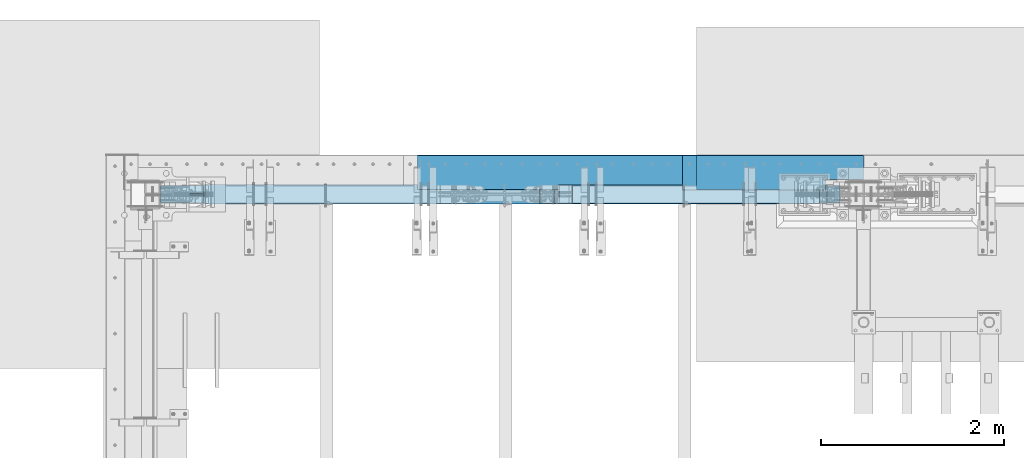
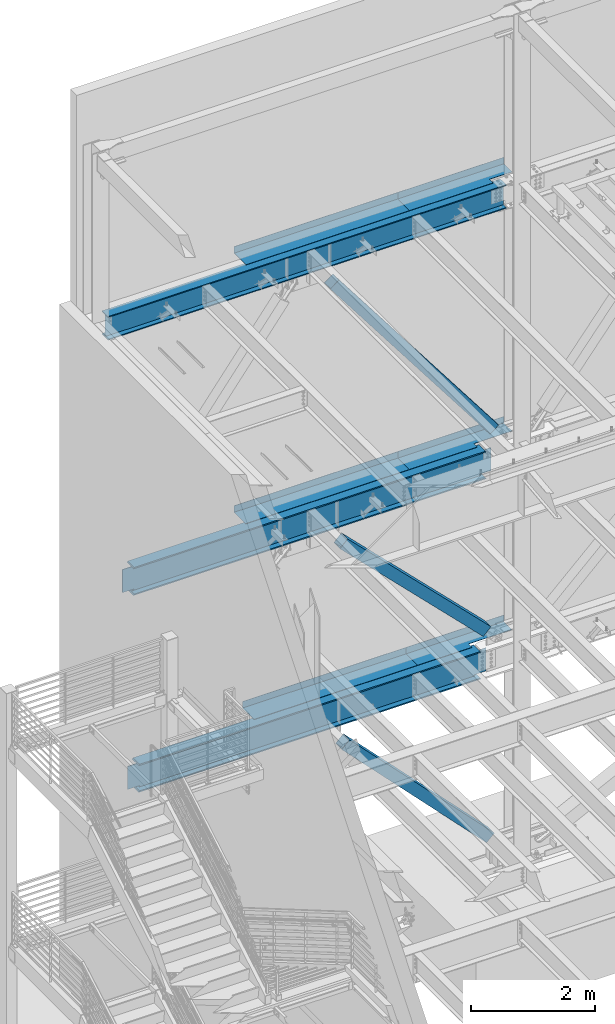
# One storey, part 769 of 1179: 9 beams, 3 members, 6 elements without a shape of their own.
"""IFC2X3 building model written with IfcOpenShell, lengths in millimetres."""

from ifc_helpers import new_model, si_unit, frame, origin_with_axes, place, context, subcontext, project, spatial, faceted_brep, material, type_object, element, aggregate, save


model = new_model("IFC2X3")

# Units and contexts
model_context = context("Model", 3, precision=1e-05, world=origin_with_axes())
body_context = subcontext(model_context, "Body", "Model", "MODEL_VIEW")
ifc_project = project(units=[si_unit("LENGTHUNIT", "METRE", prefix="MILLI"), si_unit("AREAUNIT", "SQUARE_METRE"), si_unit("VOLUMEUNIT", "CUBIC_METRE"), si_unit("MASSUNIT", "GRAM", prefix="KILO"), si_unit("TIMEUNIT", "SECOND"), si_unit("PLANEANGLEUNIT", "RADIAN"), si_unit("SOLIDANGLEUNIT", "STERADIAN"), si_unit("THERMODYNAMICTEMPERATUREUNIT", "DEGREE_CELSIUS"), si_unit("LUMINOUSINTENSITYUNIT", "LUMEN")], contexts=[model_context])

# Site, building, storey
site_placement = place(None, origin_with_axes())
site = spatial("IfcSite", under=ifc_project, at=site_placement, CompositionType="ELEMENT")
building_placement = place(site_placement, origin_with_axes())
building = spatial("IfcBuilding", under=site, at=building_placement, Name="Undefined", CompositionType="ELEMENT")
storey_placement = place(building_placement, origin_with_axes())
storey = spatial("IfcBuildingStorey", under=building, at=storey_placement, Name="Undefined", CompositionType="ELEMENT", Elevation=0.0)

# Assembly, beams
assembly_1_placement = place(storey_placement, origin_with_axes())
assembly_1 = element("IfcElementAssembly", 1, at=assembly_1_placement, inside=storey, Name="BEAM", AssemblyPlace="NOTDEFINED", PredefinedType="RIGID_FRAME")
ifc_material_1 = material(Name="STEEL/A36")
beam_type_1 = type_object("IfcBeamType", PredefinedType="NOTDEFINED")
beam_1_placement = place(assembly_1_placement, frame((7288.212, 41244.8379999672, 13122.275), z_axis=(-1.0, 0.0, 0.0), x_axis=(0.0, 1.0, 0.0)))
beam_1 = element("IfcBeam", 2, at=beam_1_placement, type_object=beam_type_1, material=ifc_material_1, Name="BENT_PLATE", context=body_context, shape_type="Brep", body=[
    faceted_brep([(117.47450003276, -3.17499999999927, -573.284734006237), (117.47450003276, 3.17499999999927, -573.284734006237), (117.47450003276, 3.17499999999927, -989.0125), (117.47450003276, -3.17499999999927, -989.0125), (0.0, -3.17499999999927, -573.284734006237), (0.0, 3.17499999999927, -573.284734006237), (385.761999997871, 3.17499999999927, 989.0125), (0.0, 3.17499999999927, 989.0125), (0.0, -3.17499999999927, 989.0125), (379.411999997865, -3.17499999999927, 989.0125), (379.411999997865, -130.17500000214, 989.0125), (385.761999997871, -130.17500000214, 989.0125), (385.761999997871, 3.17499999999927, -989.0125), (385.761999997871, -130.17500000214, -989.0125), (379.411999997865, -130.17500000214, -989.0125), (379.411999997865, -3.17499999999927, -989.0125)], [[[0, 1, 2, 3]], [[4, 5, 1, 0]], [[6, 7, 8, 9, 10, 11]], [[12, 6, 11, 13]], [[10, 14, 13, 11]], [[9, 15, 14, 10]], [[12, 13, 14, 15, 3, 2]], [[7, 6, 12, 2, 1, 5]], [[8, 7, 5, 4]], [[15, 9, 8, 4, 0, 3]]]),
])
beam_2_placement = place(assembly_1_placement, frame((4775.1995, 41244.838, 13122.275), z_axis=(-1.0, 0.0, 0.0), x_axis=(0.0, 1.0, 0.0)))
beam_2 = element("IfcBeam", 3, at=beam_2_placement, type_object=beam_type_1, material=ifc_material_1, Name="BENT_PLATE", context=body_context, shape_type="Brep", body=[
    faceted_brep([(0.0, -3.17499999999927, -1524.0), (6.00266503170133e-10, -3.17499999922438, 1524.00000000052), (6.00266503170133e-10, 3.17500000077416, 1524.00000000052), (0.0, 3.17499999999927, -1524.0), (385.762000000002, 3.17499999999927, 1524.0), (385.762000000002, 3.17499999999927, -1524.0), (379.411999999997, -3.17499999999927, -1524.0), (379.411999999997, -3.17499999999927, 1524.0), (385.762000000002, -130.175000000001, 1524.0), (385.762000000002, -130.175000000001, -1524.0), (379.411999999997, -130.175000000001, 1524.0), (379.411999999997, -130.175000000001, -1524.0)], [[[0, 1, 2, 3]], [[3, 2, 4, 5]], [[1, 0, 6, 7]], [[5, 4, 8, 9]], [[4, 2, 1, 7, 10, 8]], [[7, 6, 11, 10]], [[6, 0, 3, 5, 9, 11]], [[10, 11, 9, 8]]]),
])

assembly_2_placement = place(storey_placement, origin_with_axes())
assembly_2 = element("IfcElementAssembly", 4, at=assembly_2_placement, inside=storey, Name="BEAM", AssemblyPlace="NOTDEFINED", PredefinedType="RIGID_FRAME")
beam_type_2 = type_object("IfcBeamType", PredefinedType="NOTDEFINED")
beam_3_placement = place(assembly_2_placement, frame((7365.99998779297, 41627.425, 4235.45000610352), z_axis=(1.0, 0.0, 0.0), x_axis=(0.0, 0.0, -1.0)))
beam_3 = element("IfcBeam", 5, at=beam_3_placement, type_object=beam_type_2, material=ifc_material_1, Name="BENT_PLATE", context=body_context, shape_type="Brep", body=[
    faceted_brep([(133.350006103513, -373.062500000007, 103.381845299587), (133.350006103513, -265.112500017596, 103.381845299558), (127.000006103513, -265.112500017596, 103.381845299558), (127.000006103513, -373.062500000007, 103.381845299587), (133.350006103513, -265.112499987561, 911.224999999999), (127.000006103513, -265.112499987561, 911.224999999999), (127.000006103513, -3.17500000000291, -911.225), (0.0, -3.17500000000291, -911.225), (0.0, 3.17500000000291, -911.225), (133.350006103513, 3.17500000000291, -911.225), (133.350006103513, -373.062500000007, -911.225), (127.000006103513, -373.062500000007, -911.225), (0.0, -3.17500000000291, 911.224999999999), (127.000006103513, -3.17500000000291, 911.224999999999), (0.0, 3.17500000000291, 911.224999999999), (133.350006103513, 3.17500000000291, 911.224999999999)], [[[0, 1, 2, 3]], [[4, 5, 2, 1]], [[6, 7, 8, 9, 10, 11]], [[12, 7, 6, 13]], [[7, 12, 14, 8]], [[8, 14, 15, 9]], [[0, 10, 9, 15, 4, 1]], [[11, 10, 0, 3]], [[13, 6, 11, 3, 2, 5]], [[15, 14, 12, 13, 5, 4]]]),
])
beam_4_placement = place(assembly_2_placement, frame((4930.77498779297, 41627.425, 4235.45000610352), z_axis=(1.0, 0.0, 0.0), x_axis=(0.0, 0.0, -1.0)))
beam_4 = element("IfcBeam", 6, at=beam_4_placement, type_object=beam_type_2, material=ifc_material_1, Name="BENT_PLATE", context=body_context, shape_type="Brep", body=[
    faceted_brep([(0.0, -3.17499999999927, -1524.0), (6.00266503170133e-10, -3.17499999922438, 1524.00000000052), (6.00266503170133e-10, 3.17500000077416, 1524.00000000052), (0.0, 3.17499999999927, -1524.0), (133.350006103513, 3.17500000000291, 1524.0), (133.350006103513, 3.17500000000291, -1524.0), (127.000006103513, -3.17500000000291, -1524.0), (127.000006103513, -3.17500000000291, 1524.0), (133.350006103513, -373.062500000007, 1524.0), (133.350006103513, -373.062500000007, -1524.0), (127.000006103513, -373.062500000007, 1524.0), (127.000006103513, -373.062500000007, -1524.0)], [[[0, 1, 2, 3]], [[3, 2, 4, 5]], [[1, 0, 6, 7]], [[5, 4, 8, 9]], [[4, 2, 1, 7, 10, 8]], [[7, 6, 11, 10]], [[6, 0, 3, 5, 9, 11]], [[10, 11, 9, 8]]]),
])

assembly_3_placement = place(storey_placement, origin_with_axes())
assembly_3 = element("IfcElementAssembly", 7, at=assembly_3_placement, inside=storey, Name="BEAM", AssemblyPlace="NOTDEFINED", PredefinedType="RIGID_FRAME")
beam_5_placement = place(assembly_3_placement, frame((7288.21252306546, 41627.425, 8147.05000610352), z_axis=(1.0, 0.0, 0.0), x_axis=(0.0, 0.0, -1.0)))
beam_5 = element("IfcBeam", 8, at=beam_5_placement, type_object=beam_type_2, material=ifc_material_1, Name="BENT_PLATE", context=body_context, shape_type="Brep", body=[
    faceted_brep([(133.350006103513, -373.062500000007, 278.002633270564), (133.350006103513, -265.11250000041, 278.002633270536), (127.000006103513, -265.11250000041, 278.002633270536), (127.000006103513, -373.062500000007, 278.002633270564), (133.350006103513, -265.112499993244, 989.012500003549), (127.000006103513, -265.112499993244, 989.0125), (127.000006103513, -3.17500000000291, -989.0125), (1.46610545925796e-09, -3.17499999991014, -989.012500000246), (1.46610545925796e-09, 3.17500000008476, -989.012500000244), (133.350006103513, 3.17500000000291, -989.0125), (133.350006103513, -373.062500000007, -989.0125), (127.000006103513, -373.062500000007, -989.0125), (0.0, -3.17499999999927, 989.0125), (127.000006103513, -3.17500000000291, 989.0125), (0.0, 3.17499999999927, 989.0125), (133.350006103513, 3.17500000000291, 989.0125)], [[[0, 1, 2, 3]], [[4, 5, 2, 1]], [[6, 7, 8, 9, 10, 11]], [[12, 7, 6, 13]], [[7, 12, 14, 8]], [[8, 14, 15, 9]], [[0, 10, 9, 15, 4, 1]], [[11, 10, 0, 3]], [[13, 6, 11, 3, 2, 5]], [[15, 14, 12, 13, 5, 4]]]),
])
beam_6_placement = place(assembly_3_placement, frame((4775.20002306546, 41627.425, 8147.05000610352), z_axis=(1.0, 0.0, 0.0), x_axis=(0.0, 0.0, -1.0)))
beam_6 = element("IfcBeam", 9, at=beam_6_placement, type_object=beam_type_2, material=ifc_material_1, Name="BENT_PLATE", context=body_context, shape_type="Brep", body=[
    faceted_brep([(0.0, -3.17499999999927, -1524.0), (6.00266503170133e-10, -3.17499999922438, 1524.00000000052), (6.00266503170133e-10, 3.17500000077416, 1524.00000000052), (0.0, 3.17499999999927, -1524.0), (133.350006103513, 3.17500000000291, 1524.0), (133.350006103513, 3.17500000000291, -1524.0), (127.000006103513, -3.17500000000291, -1524.0), (127.000006103513, -3.17500000000291, 1524.0), (133.350006103513, -373.062500000007, 1524.0), (133.350006103513, -373.062500000007, -1524.0), (127.000006103513, -373.062500000007, 1524.0), (127.000006103513, -373.062500000007, -1524.0)], [[[0, 1, 2, 3]], [[3, 2, 4, 5]], [[1, 0, 6, 7]], [[5, 4, 8, 9]], [[4, 2, 1, 7, 10, 8]], [[7, 6, 11, 10]], [[6, 0, 3, 5, 9, 11]], [[10, 11, 9, 8]]]),
])

# Assembly, member
assembly_4_placement = place(storey_placement, origin_with_axes())
assembly_4 = element("IfcElementAssembly", 10, at=assembly_4_placement, inside=storey, Name="None", AssemblyPlace="NOTDEFINED", PredefinedType="RIGID_FRAME")
ifc_material_2 = material(Name="STEEL/A992")
member_type = type_object("IfcMemberType", Name="HSS8X8X3/16", PredefinedType="NOTDEFINED")
member_1_placement = place(assembly_4_placement, frame((7795.83270338898, 41198.8, 8374.56702188533), z_axis=(0.0, 1.0, 0.0), x_axis=(-0.606338778903741, 0.0, 0.795206441873756)))
member_1 = element("IfcMember", 11, at=member_1_placement, type_object=member_type, material=ifc_material_2, Name="None", ObjectType="HSS8X8X3/16", context=body_context, shape_type="Brep", body=[
    faceted_brep([(-3.63797880709171e-12, 96.8374999999978, -96.8375000000015), (-3.63797880709171e-12, -96.8374999999978, -96.8375000000015), (4906.40493070656, -96.8375000009946, -96.8375000000015), (4906.4049307065, 96.8374999990483, -96.8375000000015), (-3.63797880709171e-12, -96.8374999999978, 96.8375000000015), (4906.40493070656, -96.8375000009946, 96.8375000000015), (-3.63797880709171e-12, 96.8374999999978, 96.8375000000015), (4906.4049307065, 96.8374999990483, 96.8375000000015), (-3.63797880709171e-12, 101.599999999999, -101.599999999999), (-3.63797880709171e-12, 101.599999999999, 101.599999999999), (4906.40493070649, 101.599999999049, 101.599999999999), (4906.40493070649, 101.599999999049, -101.599999999999), (0.0, -101.599999999999, 101.599999999999), (4906.40493070656, -101.600000000995, 101.599999999999), (0.0, -101.599999999999, -101.599999999999), (4906.40493070656, -101.600000000995, -101.599999999999)], [[[0, 1, 2, 3]], [[1, 4, 5, 2]], [[4, 6, 7, 5]], [[6, 0, 3, 7]], [[8, 9, 10, 11]], [[9, 12, 13, 10]], [[12, 14, 15, 13]], [[14, 8, 11, 15]], [[13, 15, 11, 10], [5, 7, 3, 2]], [[14, 12, 9, 8], [6, 4, 1, 0]]]),
])
aggregate(assembly_4, [member_1])

assembly_5_placement = place(storey_placement, origin_with_axes())
assembly_5 = element("IfcElementAssembly", 12, at=assembly_5_placement, inside=storey, Name="None", AssemblyPlace="NOTDEFINED", PredefinedType="RIGID_FRAME")
member_2_placement = place(assembly_5_placement, frame((7661.13560118178, 41198.8, 4444.72280543837), z_axis=(0.0, 1.0, 0.0), x_axis=(-0.708251890968841, 0.0, 0.705959813968941)))
member_2 = element("IfcMember", 13, at=member_2_placement, type_object=member_type, material=ifc_material_2, Name="None", ObjectType="HSS8X8X3/16", context=body_context, shape_type="Brep", body=[
    faceted_brep([(-3.63797880709171e-12, 96.8374999999978, -96.8375000000015), (-3.63797880709171e-12, -96.8374999999978, -96.8375000000015), (3770.52536925462, -96.837500002066, -96.8375000000015), (3770.52536925472, 96.8374999979314, -96.8375000000015), (-3.63797880709171e-12, -96.8374999999978, 96.8375000000015), (3770.52536925462, -96.837500002066, 96.8375000000015), (-3.63797880709171e-12, 96.8374999999978, 96.8375000000015), (3770.52536925472, 96.8374999979314, 96.8375000000015), (-3.63797880709171e-12, 101.599999999999, -101.599999999999), (-3.63797880709171e-12, 101.599999999999, 101.599999999999), (3770.52536925473, 101.599999997932, 101.599999999999), (3770.52536925473, 101.599999997932, -101.599999999999), (0.0, -101.599999999999, 101.599999999999), (3770.52536925462, -101.600000002065, 101.599999999999), (0.0, -101.599999999999, -101.599999999999), (3770.52536925462, -101.600000002065, -101.599999999999)], [[[0, 1, 2, 3]], [[1, 4, 5, 2]], [[4, 6, 7, 5]], [[6, 0, 3, 7]], [[8, 9, 10, 11]], [[9, 12, 13, 10]], [[12, 14, 15, 13]], [[14, 8, 11, 15]], [[13, 15, 11, 10], [5, 7, 3, 2]], [[14, 12, 9, 8], [6, 4, 1, 0]]]),
])
aggregate(assembly_5, [member_2])

assembly_6_placement = place(storey_placement, origin_with_axes())
assembly_6 = element("IfcElementAssembly", 14, at=assembly_6_placement, inside=storey, Name="None", AssemblyPlace="NOTDEFINED", PredefinedType="RIGID_FRAME")
member_3_placement = place(assembly_6_placement, frame((7724.35557066921, 41198.8, 357.014705944042), z_axis=(0.0, 1.0, 0.0), x_axis=(-0.696462576035121, 0.0, 0.717593116036186)))
member_3 = element("IfcMember", 15, at=member_3_placement, type_object=member_type, material=ifc_material_2, Name="None", ObjectType="HSS8X8X3/16", context=body_context, shape_type="Brep", body=[
    faceted_brep([(-3.63797880709171e-12, 96.8374999999978, -96.8375000000015), (-3.63797880709171e-12, -96.8374999999978, -96.8375000000015), (3876.67499999912, -96.8374999988628, -96.8375000000015), (3876.67499999909, 96.837500001162, -96.8375000000015), (-3.63797880709171e-12, -96.8374999999978, 96.8375000000015), (3876.67499999912, -96.8374999988628, 96.8375000000015), (-3.63797880709171e-12, 96.8374999999978, 96.8375000000015), (3876.67499999909, 96.837500001162, 96.8375000000015), (-3.63797880709171e-12, 101.599999999999, -101.599999999999), (-3.63797880709171e-12, 101.599999999999, 101.599999999999), (3876.67499999909, 101.600000001163, 101.599999999999), (3876.67499999909, 101.600000001163, -101.599999999999), (0.0, -101.599999999999, 101.599999999999), (3876.67499999912, -101.599999998863, 101.599999999999), (0.0, -101.599999999999, -101.599999999999), (3876.67499999912, -101.599999998863, -101.599999999999)], [[[0, 1, 2, 3]], [[1, 4, 5, 2]], [[4, 6, 7, 5]], [[6, 0, 3, 7]], [[8, 9, 10, 11]], [[9, 12, 13, 10]], [[12, 14, 15, 13]], [[14, 8, 11, 15]], [[13, 15, 11, 10], [5, 7, 3, 2]], [[14, 12, 9, 8], [6, 4, 1, 0]]]),
])
aggregate(assembly_6, [member_3])

# Beam
beam_type_3 = type_object("IfcBeamType", Name="W18X65", PredefinedType="NOTDEFINED")
beam_7_placement = place(assembly_1_placement, frame((431.8, 41198.8, 12885.7375), z_axis=(0.0, 0.0, 1.0), x_axis=(1.0, 0.0, 0.0)))
beam_7 = element("IfcBeam", 16, at=beam_7_placement, type_object=beam_type_3, material=ifc_material_2, Name="BEAM", ObjectType="W18X65", context=body_context, shape_type="Brep", body=[
    faceted_brep([(166.6875, -96.8375000000015, -233.362499999999), (166.6875, 96.8375000000015, -233.362499999999), (7588.25, 96.8375000000015, -233.362499999999), (7588.25, -96.8375000000015, -233.362499999999), (166.6875, -96.8375000000015, -214.3125), (166.6875, -5.55625000000146, -214.3125), (166.6875, -5.55625000000146, -129.327499999974), (166.6875, -5.55625000000146, 189.652500000133), (166.6875, -5.55625000000146, 214.3125), (166.6875, -96.8375000000015, 214.3125), (166.6875, -96.8375000000015, 233.362499999999), (166.6875, 96.8375000000015, 233.362499999999), (166.6875, 96.8375000000015, 214.3125), (166.6875, 5.55625000000146, 214.3125), (166.6875, 5.55625000000146, -214.3125), (166.6875, 96.8375000000015, -214.3125), (7588.25, -96.8375000000015, -214.3125), (7588.25, -5.55625000000146, -214.3125), (7588.25, -5.55625000000146, -122.977499999977), (7588.25, -5.55625000000146, 183.302500000127), (7588.25, -5.55625000000146, 214.3125), (7588.25, -96.8375000000015, 214.3125), (7588.25, -96.8375000000015, 233.362499999999), (7588.25, 96.8375000000015, 233.362499999999), (7588.25, 96.8375000000015, 214.3125), (7588.25, 5.55625000000146, 214.3125), (7588.25, 5.55625000000146, -214.3125), (7588.25, 96.8375000000015, -214.3125)], [[[0, 1, 2, 3]], [[0, 4, 5, 6, 7, 8, 9, 10, 11, 12, 13, 14, 15, 1]], [[5, 4, 16, 17]], [[8, 7, 6, 5, 17, 18, 19, 20]], [[9, 8, 20, 21]], [[10, 9, 21, 22]], [[11, 10, 22, 23]], [[12, 11, 23, 24]], [[13, 12, 24, 25]], [[14, 13, 25, 26]], [[15, 14, 26, 27]], [[1, 15, 27, 2]], [[26, 25, 24, 23, 22, 21, 20, 19, 18, 17, 16, 3, 2, 27]], [[4, 0, 3, 16]]]),
])

aggregate(assembly_1, [beam_1, beam_2, beam_7])

beam_type_4 = type_object("IfcBeamType", Name="W21X93", PredefinedType="NOTDEFINED")
beam_8_placement = place(assembly_3_placement, frame((431.8, 41198.8, 7739.0625), z_axis=(0.0, 0.0, 1.0), x_axis=(1.0, 0.0, 0.0)))
beam_8 = element("IfcBeam", 17, at=beam_8_placement, type_object=beam_type_4, material=ifc_material_2, Name="BEAM", ObjectType="W21X93", context=body_context, shape_type="Brep", body=[
    faceted_brep([(651.733401432473, -106.362500000003, 274.6375), (651.733401432473, 106.362500000003, 274.6375), (637.98484446673, 106.362500000003, 250.825), (637.98484446673, 7.14375000000291, 250.825), (637.755629679731, 7.14375000000291, 250.428), (637.755629679731, -7.14375000000291, 250.428), (637.98484446673, -7.14375000000291, 250.825), (637.98484446673, -106.362500000003, 250.825), (680.84783100647, -7.14375000000291, 250.428), (680.84783100647, 7.14375000000291, 250.428), (695.424195203474, 7.14375000000291, 243.568356973128), (695.424195203474, -7.14375000000291, 243.568356973128), (699.27994381252, 7.14375000000291, 240.254052423033), (699.27994381252, -7.14375000000291, 240.254052423033), (700.881370287269, 7.14375000000291, 235.428407882362), (700.881370287269, -7.14375000000291, 235.428407882362), (699.772163206537, 7.14375000000291, 230.466445403767), (699.772163206537, -7.14375000000291, 230.466445403767), (696.268380701856, 7.14375000000291, 226.782029554974), (696.268380701856, -7.14375000000291, 226.782029554974), (691.368392663723, 7.14375000000291, 225.425), (691.368392663723, -7.14375000000291, 225.425), (488.75983100647, 7.14375000000291, 225.425), (488.75983100647, -7.14375000000291, 225.425), (488.75983100647, 7.14375000000291, -225.425), (488.75983100647, -7.14375000000291, -225.425), (694.462392663723, 7.14375000000291, -225.425), (694.462392663723, -7.14375000000291, -225.425), (699.362380701857, 7.14375000000291, -226.782029554975), (699.362380701857, -7.14375000000291, -226.782029554975), (702.866163206538, 7.14375000000291, -230.466445403767), (702.866163206538, -7.14375000000291, -230.466445403767), (703.97537028727, 7.14375000000291, -235.428407882363), (703.97537028727, -7.14375000000291, -235.428407882363), (702.373943812521, 7.14375000000291, -240.254052423033), (702.373943812521, -7.14375000000291, -240.254052423033), (698.518195203475, 7.14375000000291, -243.568356973128), (698.518195203475, -7.14375000000291, -243.568356973128), (683.94183100647, 7.14375000000291, -250.428), (683.94183100647, -7.14375000000291, -250.428), (651.962622723169, 7.14375000000291, -250.428), (651.962622723169, -7.14375000000291, -250.428), (7196.86658636288, 7.14375000000291, -250.825), (7196.86658636288, 106.362500000003, -250.825), (651.733414439867, 106.362500000003, -250.825), (651.733414439867, 7.14375000000291, -250.825), (7210.61475322968, 106.362500000003, -274.6375), (637.985247573073, 106.362500000003, -274.6375), (7210.61475322968, -106.362500000003, -274.6375), (637.985247573073, -106.362500000003, -274.6375), (7196.86658636288, -106.362500000003, -250.825), (651.733414439867, -106.362500000003, -250.825), (651.733414439867, -7.14375000000291, -250.825), (7196.86658636288, -7.14375000000291, -250.825), (7196.63737807958, 7.14375000000291, -250.428), (7196.63737807958, -7.14375000000291, -250.428), (7164.65816979628, 7.14375000000291, -250.428), (7164.65816979628, -7.14375000000291, -250.428), (7150.08180559927, 7.14375000000291, -243.568356973128), (7150.08180559927, -7.14375000000291, -243.568356973128), (7146.22605699023, 7.14375000000291, -240.254052423033), (7146.22605699023, -7.14375000000291, -240.254052423033), (7144.62463051548, 7.14375000000291, -235.428407882363), (7144.62463051548, -7.14375000000291, -235.428407882363), (7145.73383759621, 7.14375000000291, -230.466445403767), (7145.73383759621, -7.14375000000291, -230.466445403767), (7149.23762010089, 7.14375000000291, -226.782029554975), (7149.23762010089, -7.14375000000291, -226.782029554975), (7154.13760813903, 7.14375000000291, -225.425), (7154.13760813903, -7.14375000000291, -225.425), (7359.84016979628, 7.14375000000291, -225.425), (7359.84016979628, -7.14375000000291, -225.425), (7359.84016979628, -7.14375000000291, 225.425), (7359.84016979628, 7.14375000000291, 225.425), (7157.23160813903, 7.14375000000291, 225.425), (7157.23160813903, -7.14375000000291, 225.425), (7152.33162010089, 7.14375000000291, 226.782029554975), (7152.33162010089, -7.14375000000291, 226.782029554975), (7148.82783759621, 7.14375000000291, 230.466445403768), (7148.82783759621, -7.14375000000291, 230.466445403768), (7147.71863051548, 7.14375000000291, 235.428407882364), (7147.71863051548, -7.14375000000291, 235.428407882364), (7149.32005699023, 7.14375000000291, 240.254052423034), (7149.32005699023, -7.14375000000291, 240.254052423034), (7153.17580559928, 7.14375000000291, 243.568356973128), (7153.17580559928, -7.14375000000291, 243.568356973128), (7167.75216979628, 7.14375000000291, 250.428), (7167.75216979628, -7.14375000000291, 250.428), (7210.84437112302, 7.14375000000291, 250.428), (7210.84437112302, -7.14375000000291, 250.428), (7210.61515633602, -106.362500000003, 250.825), (7210.61515633602, -7.14375000000291, 250.825), (7210.61515633602, 7.14375000000291, 250.825), (7210.61515633602, 106.362500000003, 250.825), (7196.86659937028, 106.362500000003, 274.6375), (7196.86659937028, -106.362500000003, 274.6375)], [[[0, 1, 2, 3, 4, 5, 6, 7]], [[8, 9, 10, 11]], [[11, 10, 12, 13]], [[13, 12, 14, 15]], [[15, 14, 16, 17]], [[17, 16, 18, 19]], [[19, 18, 20, 21]], [[21, 20, 22, 23]], [[23, 22, 24, 25]], [[26, 27, 25, 24]], [[27, 26, 28, 29]], [[29, 28, 30, 31]], [[31, 30, 32, 33]], [[33, 32, 34, 35]], [[35, 34, 36, 37]], [[37, 36, 38, 39]], [[39, 38, 40, 41]], [[42, 43, 44, 45]], [[43, 46, 47, 44]], [[46, 48, 49, 47]], [[48, 50, 51, 49]], [[41, 40, 45, 44, 47, 49, 51, 52]], [[50, 53, 52, 51]], [[48, 46, 43, 42, 54, 55, 53, 50]], [[56, 57, 55, 54]], [[57, 56, 58, 59]], [[59, 58, 60, 61]], [[61, 60, 62, 63]], [[63, 62, 64, 65]], [[65, 64, 66, 67]], [[67, 66, 68, 69]], [[69, 68, 70, 71]], [[72, 71, 70, 73]], [[74, 75, 72, 73]], [[75, 74, 76, 77]], [[77, 76, 78, 79]], [[79, 78, 80, 81]], [[81, 80, 82, 83]], [[83, 82, 84, 85]], [[85, 84, 86, 87]], [[87, 86, 88, 89]], [[90, 91, 89, 88, 92, 93, 94, 95]], [[90, 95, 0, 7]], [[91, 90, 7, 6]], [[8, 11, 13, 15, 17, 19, 21, 23, 25, 27, 29, 31, 33, 35, 37, 39, 41, 52, 53, 55, 57, 59, 61, 63, 65, 67, 69, 71, 72, 75, 77, 79, 81, 83, 85, 87, 89, 91, 6, 5]], [[9, 8, 5, 4]], [[92, 88, 86, 84, 82, 80, 78, 76, 74, 73, 70, 68, 66, 64, 62, 60, 58, 56, 54, 42, 45, 40, 38, 36, 34, 32, 30, 28, 26, 24, 22, 20, 18, 16, 14, 12, 10, 9, 4, 3]], [[93, 92, 3, 2]], [[94, 93, 2, 1]], [[95, 94, 1, 0]]]),
])

aggregate(assembly_3, [beam_5, beam_6, beam_8])

beam_9_placement = place(assembly_2_placement, frame((431.8, 41198.8, 3827.4625), z_axis=(0.0, 0.0, 1.0), x_axis=(1.0, 0.0, 0.0)))
beam_9 = element("IfcBeam", 18, at=beam_9_placement, type_object=beam_type_4, material=ifc_material_2, Name="BEAM", ObjectType="W21X93", context=body_context, shape_type="Brep", body=[
    faceted_brep([(7113.78183309255, -106.362500000003, 250.825), (7113.78183309255, -7.14375000000291, 250.825), (7114.01104787955, -7.14375000000291, 250.428), (7114.01104787955, 7.14375000000291, 250.428), (7113.78183309255, 7.14375000000291, 250.825), (7113.78183309255, 106.362500000003, 250.825), (7100.03327612681, 106.362500000003, 274.6375), (7100.03327612681, -106.362500000003, 274.6375), (748.566736004796, -106.362500000003, -250.825), (734.818569138002, -106.362500000003, -274.6375), (7113.78142998621, -106.362500000003, -274.6375), (7100.03326311942, -106.362500000003, -250.825), (734.818569138002, 106.362500000003, -274.6375), (7113.78142998621, 106.362500000003, -274.6375), (748.566736004796, 106.362500000003, -250.825), (7100.03326311942, 106.362500000003, -250.825), (748.566736004796, 7.14375000000291, -250.825), (7100.03326311942, 7.14375000000291, -250.825), (7043.11926963974, -7.14375000000291, 243.9235336661), (7043.11926963974, 7.14375000000291, 243.9235336661), (7061.39384655281, 7.14375000000291, 250.428), (7061.39384655281, -7.14375000000291, 250.428), (7038.84093085742, -7.14375000000291, 240.856821654457), (7038.84093085742, 7.14375000000291, 240.856821654457), (7036.84473569238, -7.14375000000291, 235.986081447698), (7036.84473569238, 7.14375000000291, 235.986081447698), (7037.74035078749, -7.14375000000291, 230.798906985616), (7037.74035078749, 7.14375000000291, 230.798906985616), (7041.25424244329, -7.14375000000291, 226.879535769469), (7041.25424244329, 7.14375000000291, 226.879535769469), (7046.3132177342, -7.14375000000291, 225.424999999999), (7046.3132177342, 7.14375000000291, 225.424999999999), (7263.00684655281, -7.14375000000291, 225.424999999999), (7263.00684655281, 7.14375000000291, 225.424999999999), (7263.00684655281, -7.14375000000291, -225.424999999999), (7263.00684655281, 7.14375000000291, -225.424999999999), (7046.3942177342, -7.14375000000291, -225.424999999999), (7046.3942177342, 7.14375000000291, -225.424999999999), (7041.3352424433, -7.14375000000291, -226.879535769469), (7041.3352424433, 7.14375000000291, -226.879535769469), (7037.82135078749, -7.14375000000291, -230.798906985615), (7037.82135078749, 7.14375000000291, -230.798906985615), (7036.92573569238, -7.14375000000291, -235.986081447697), (7036.92573569238, 7.14375000000291, -235.986081447697), (7038.92193085742, -7.14375000000291, -240.856821654456), (7038.92193085742, 7.14375000000291, -240.856821654456), (7043.20026963974, -7.14375000000291, -243.9235336661), (7043.20026963974, 7.14375000000291, -243.9235336661), (7061.47484655281, -7.14375000000291, -250.428), (7061.47484655281, 7.14375000000291, -250.428), (7099.80405483611, -7.14375000000291, -250.428), (7099.80405483612, 7.14375000000291, -250.428), (7100.03326311942, -7.14375000000291, -250.825), (748.566736004796, -7.14375000000291, -250.825), (748.795944288098, -7.14375000000291, -250.428), (748.795944288098, 7.14375000000291, -250.428), (787.125152571399, -7.14375000000291, -250.428), (787.125152571399, 7.14375000000291, -250.428), (805.399729484465, -7.14375000000291, -243.923533666101), (805.399729484465, 7.14375000000291, -243.923533666101), (809.678068266786, -7.14375000000291, -240.856821654458), (809.678068266786, 7.14375000000291, -240.856821654458), (811.674263431827, -7.14375000000291, -235.986081447699), (811.674263431827, 7.14375000000291, -235.986081447699), (810.778648336716, -7.14375000000291, -230.798906985616), (810.778648336716, 7.14375000000291, -230.798906985616), (807.264756680914, -7.14375000000291, -226.87953576947), (807.264756680914, 7.14375000000291, -226.87953576947), (802.205781390007, -7.14375000000291, -225.425), (802.205781390007, 7.14375000000291, -225.425), (585.593152571399, -7.14375000000291, -225.425), (585.593152571399, 7.14375000000291, -225.425), (585.593152571399, -7.14375000000291, 225.425), (585.593152571399, 7.14375000000291, 225.425), (802.286781390006, -7.14375000000291, 225.425000000001), (802.286781390006, 7.14375000000291, 225.425000000001), (807.345756680915, -7.14375000000291, 226.879535769468), (807.345756680915, 7.14375000000291, 226.879535769468), (810.859648336717, -7.14375000000291, 230.798906985615), (810.859648336717, 7.14375000000291, 230.798906985615), (811.755263431828, -7.14375000000291, 235.986081447698), (811.755263431828, 7.14375000000291, 235.986081447698), (809.759068266787, -7.14375000000291, 240.856821654457), (809.759068266787, 7.14375000000291, 240.856821654457), (805.480729484464, -7.14375000000291, 243.923533666102), (805.480729484464, 7.14375000000291, 243.923533666102), (787.206152571399, -7.14375000000291, 250.428), (787.206152571399, 7.14375000000291, 250.428), (734.58895124466, -7.14375000000291, 250.428), (734.58895124466, 7.14375000000291, 250.428), (748.566722997403, -106.362500000003, 274.6375), (748.566722997403, 106.362500000003, 274.6375), (734.818166031658, 106.362500000003, 250.825), (734.818166031658, 7.14375000000291, 250.825), (734.818166031658, -7.14375000000291, 250.825), (734.818166031658, -106.362500000003, 250.825)], [[[0, 1, 2, 3, 4, 5, 6, 7]], [[8, 9, 10, 11]], [[9, 12, 13, 10]], [[12, 14, 15, 13]], [[14, 16, 17, 15]], [[18, 19, 20, 21]], [[22, 23, 19, 18]], [[24, 25, 23, 22]], [[26, 27, 25, 24]], [[28, 29, 27, 26]], [[30, 31, 29, 28]], [[31, 30, 32, 33]], [[32, 34, 35, 33]], [[36, 37, 35, 34]], [[38, 39, 37, 36]], [[40, 41, 39, 38]], [[42, 43, 41, 40]], [[44, 45, 43, 42]], [[46, 47, 45, 44]], [[48, 49, 47, 46]], [[49, 48, 50, 51]], [[10, 13, 15, 17, 51, 50, 52, 11]], [[53, 8, 11, 52]], [[54, 55, 16, 14, 12, 9, 8, 53]], [[56, 57, 55, 54]], [[58, 59, 57, 56]], [[60, 61, 59, 58]], [[62, 63, 61, 60]], [[64, 65, 63, 62]], [[66, 67, 65, 64]], [[68, 69, 67, 66]], [[69, 68, 70, 71]], [[72, 73, 71, 70]], [[74, 75, 73, 72]], [[76, 77, 75, 74]], [[78, 79, 77, 76]], [[80, 81, 79, 78]], [[82, 83, 81, 80]], [[84, 85, 83, 82]], [[86, 87, 85, 84]], [[87, 86, 88, 89]], [[90, 91, 92, 93, 89, 88, 94, 95]], [[90, 95, 0, 7]], [[91, 90, 7, 6]], [[92, 91, 6, 5]], [[93, 92, 5, 4]], [[20, 19, 23, 25, 27, 29, 31, 33, 35, 37, 39, 41, 43, 45, 47, 49, 51, 17, 16, 55, 57, 59, 61, 63, 65, 67, 69, 71, 73, 75, 77, 79, 81, 83, 85, 87, 89, 93, 4, 3]], [[21, 20, 3, 2]], [[94, 88, 86, 84, 82, 80, 78, 76, 74, 72, 70, 68, 66, 64, 62, 60, 58, 56, 54, 53, 52, 50, 48, 46, 44, 42, 40, 38, 36, 34, 32, 30, 28, 26, 24, 22, 18, 21, 2, 1]], [[95, 94, 1, 0]]]),
])

aggregate(assembly_2, [beam_3, beam_4, beam_9])

save(model, "model.ifc")
